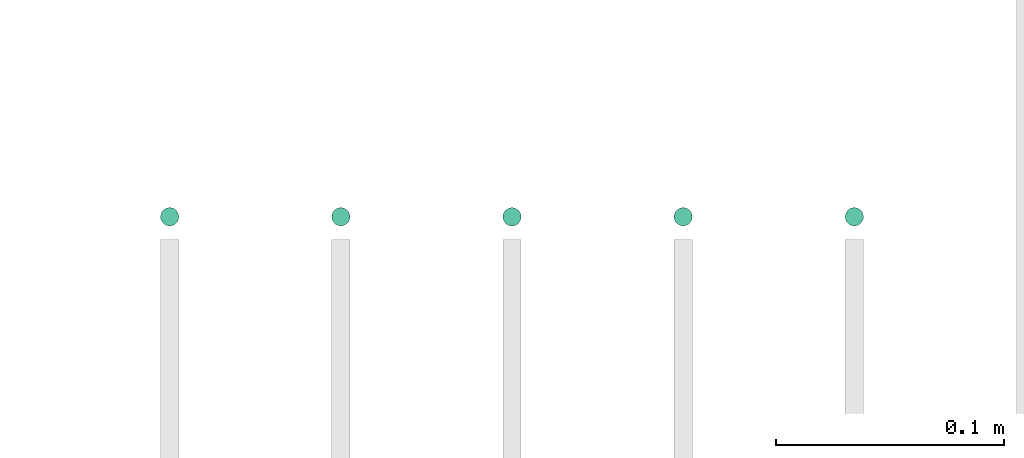
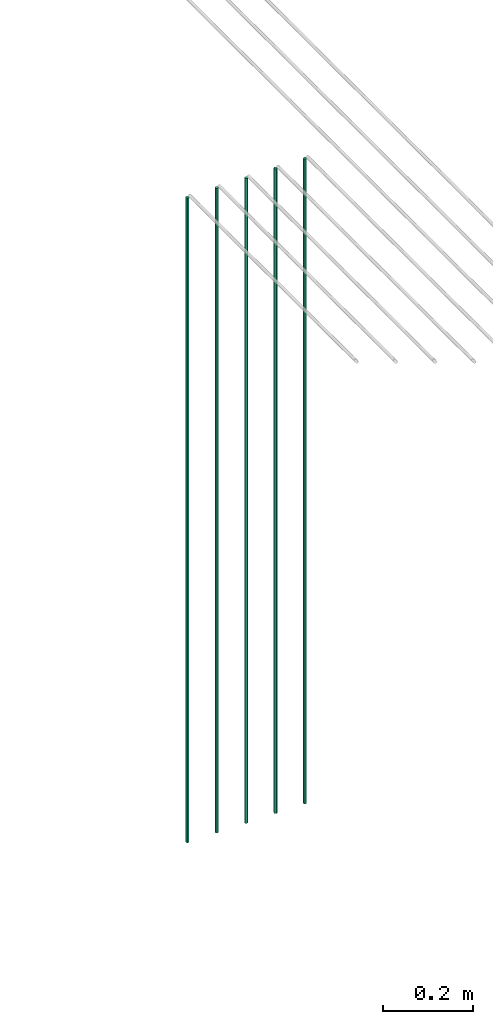
# One storey, part 4 of 89: 5 flow segments.
"""IFC2X3 building model written with IfcOpenShell, lengths in millimetres."""

from ifc_helpers import new_model, entity, si_unit, converted_unit, derived_unit, direction, frame, origin, origin_2d_with_axis, place, context, subcontext, project, spatial, circle, extrude, type_object, element, save


model = new_model("IFC2X3")

# Units and contexts
model_context = context("Model", 3, precision=0.01, world=origin(), true_north=direction((6.12303176911189e-17, 1.0)))
body_context = subcontext(model_context, "Body", "Model", "MODEL_VIEW")
ifc_project = project(units=[si_unit("LENGTHUNIT", "METRE", prefix="MILLI"), si_unit("AREAUNIT", "SQUARE_METRE"), si_unit("VOLUMEUNIT", "CUBIC_METRE"), converted_unit("PLANEANGLEUNIT", "DEGREE", entity("IfcRatioMeasure", 0.0174532925199433), si_unit("PLANEANGLEUNIT", "RADIAN"), dimensions=[0, 0, 0, 0, 0, 0, 0]), si_unit("MASSUNIT", "GRAM", prefix="KILO"), derived_unit("MASSDENSITYUNIT", [(si_unit("MASSUNIT", "GRAM", prefix="KILO"), 1), (si_unit("LENGTHUNIT", "METRE"), -3)]), derived_unit("MOMENTOFINERTIAUNIT", [(si_unit("LENGTHUNIT", "METRE"), 4)]), si_unit("TIMEUNIT", "SECOND"), si_unit("FREQUENCYUNIT", "HERTZ"), si_unit("THERMODYNAMICTEMPERATUREUNIT", "DEGREE_CELSIUS"), derived_unit("THERMALTRANSMITTANCEUNIT", [(si_unit("MASSUNIT", "GRAM", prefix="KILO"), 1), (si_unit("THERMODYNAMICTEMPERATUREUNIT", "KELVIN"), -1), (si_unit("TIMEUNIT", "SECOND"), -3)]), derived_unit("VOLUMETRICFLOWRATEUNIT", [(si_unit("LENGTHUNIT", "METRE"), 3), (si_unit("TIMEUNIT", "SECOND"), -1)]), derived_unit("MASSFLOWRATEUNIT", [(si_unit("MASSUNIT", "GRAM", prefix="KILO"), 1), (si_unit("TIMEUNIT", "SECOND"), -1)]), derived_unit("ROTATIONALFREQUENCYUNIT", [(si_unit("TIMEUNIT", "SECOND"), -1)]), si_unit("ELECTRICCURRENTUNIT", "AMPERE"), si_unit("ELECTRICVOLTAGEUNIT", "VOLT"), si_unit("POWERUNIT", "WATT"), si_unit("FORCEUNIT", "NEWTON", prefix="KILO"), si_unit("ILLUMINANCEUNIT", "LUX"), si_unit("LUMINOUSFLUXUNIT", "LUMEN"), si_unit("LUMINOUSINTENSITYUNIT", "CANDELA"), derived_unit("USERDEFINED", [(si_unit("MASSUNIT", "GRAM", prefix="KILO"), -1), (si_unit("LENGTHUNIT", "METRE"), -2), (si_unit("TIMEUNIT", "SECOND"), 3), (si_unit("LUMINOUSFLUXUNIT", "LUMEN"), 1)]), derived_unit("LINEARVELOCITYUNIT", [(si_unit("LENGTHUNIT", "METRE"), 1), (si_unit("TIMEUNIT", "SECOND"), -1)]), si_unit("PRESSUREUNIT", "PASCAL"), derived_unit("USERDEFINED", [(si_unit("LENGTHUNIT", "METRE"), -2), (si_unit("MASSUNIT", "GRAM", prefix="KILO"), 1), (si_unit("TIMEUNIT", "SECOND"), -2)]), derived_unit("LINEARFORCEUNIT", [(si_unit("MASSUNIT", "GRAM", prefix="KILO"), 1), (si_unit("LENGTHUNIT", "METRE"), 1), (si_unit("TIMEUNIT", "SECOND"), -2), (si_unit("LENGTHUNIT", "METRE"), -1)]), derived_unit("PLANARFORCEUNIT", [(si_unit("MASSUNIT", "GRAM", prefix="KILO"), 1), (si_unit("LENGTHUNIT", "METRE"), 1), (si_unit("TIMEUNIT", "SECOND"), -2), (si_unit("LENGTHUNIT", "METRE"), -2)])], contexts=[model_context])

# Site, building, storey
site_placement = place(None, frame((0.0, -0.00077364408347762, 0.0)))
site = spatial("IfcSite", under=ifc_project, at=site_placement, CompositionType="ELEMENT")
building_placement = place(site_placement, origin())
building = spatial("IfcBuilding", under=site, at=building_placement, CompositionType="ELEMENT")
storey_placement = place(building_placement, frame((0.0, 0.0, 24000.0)))
storey = spatial("IfcBuildingStorey", under=building, at=storey_placement, CompositionType="ELEMENT", Elevation=24000.0)

# Flow segments
pipe_segment_type = type_object("IfcPipeSegmentType", PredefinedType="NOTDEFINED")
for number, where in (
    (1, (44495.5981151137, 5364.40906560602, 1400.0)),
    (2, (44570.5981151137, 5364.40906560602, 1400.0)),
    (3, (44645.5981151137, 5364.40906560602, 1400.0)),
    (4, (44720.5981151137, 5364.40906560601, 1400.0)),
):
    element("IfcFlowSegment", number, at=place(storey_placement, frame(where)), inside=storey, type_object=pipe_segment_type, context=body_context, shape_type="SweptSolid", body=[
        extrude(circle(Radius=4.0, at=origin_2d_with_axis()), frame((5.59527223591499, 5.59527223591607, 0.0)), (0.0, 0.0, 1.0), 1739.99999999999),
    ])
flow_segment_placement = place(storey_placement, frame((44795.5981151137, 5364.40906560602, 1400.0)))
element("IfcFlowSegment", 5, at=flow_segment_placement, inside=storey, type_object=pipe_segment_type, context=body_context, shape_type="SweptSolid", body=[
    extrude(circle(Radius=4.0, at=origin_2d_with_axis()), frame((5.59527223591499, 5.59527223591607, 0.0)), (0.0, 0.0, 1.0), 1740.0),
])

save(model, "model.ifc")
